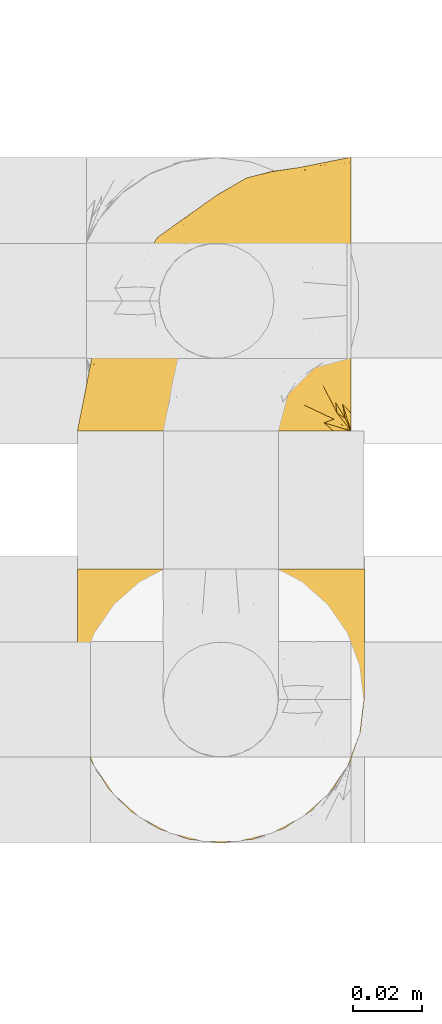
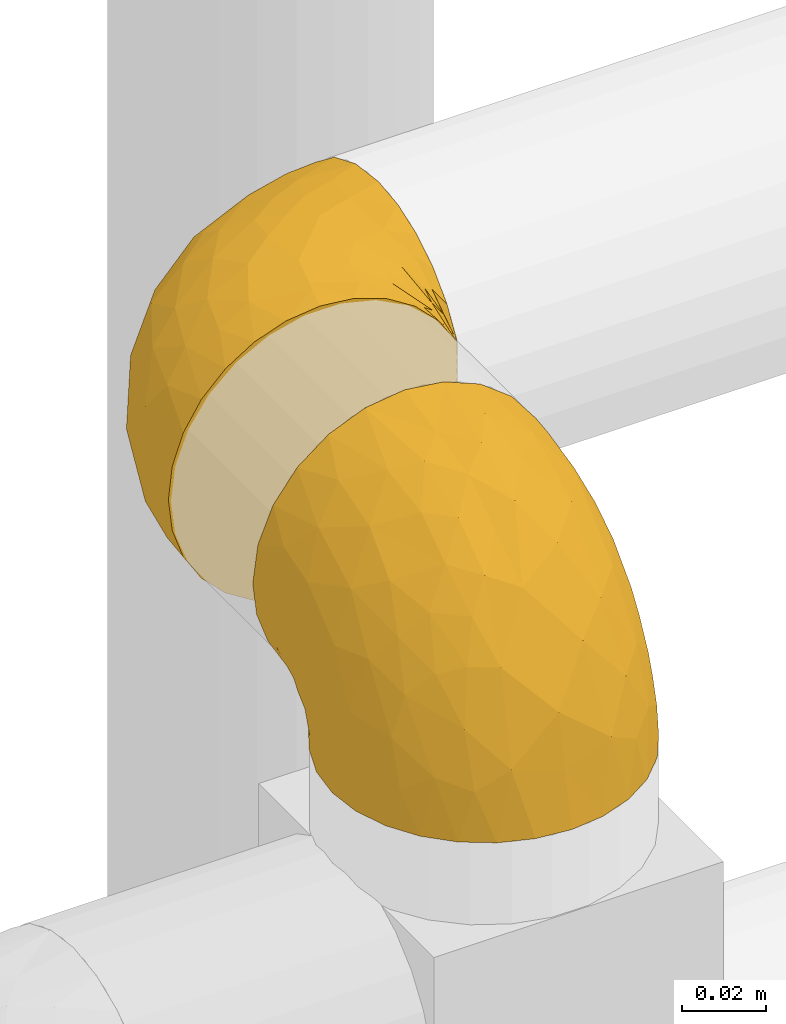
# One storey, part 443 of 827: 2 coverings.
"""IFC2X3 building model written with IfcOpenShell, lengths in millimetres."""

from ifc_helpers import new_model, entity, si_unit, converted_unit, derived_unit, direction, frame, origin, place, context, subcontext, project, spatial, faceted_brep, element, save


model = new_model("IFC2X3")

# Units and contexts
model_context = context("Model", 3, precision=0.01, world=origin(), true_north=direction((6.12303176911189e-17, 1.0)))
body_context = subcontext(model_context, "Body", "Model", "MODEL_VIEW")
ifc_project = project(units=[si_unit("LENGTHUNIT", "METRE", prefix="MILLI"), si_unit("AREAUNIT", "SQUARE_METRE"), si_unit("VOLUMEUNIT", "CUBIC_METRE"), converted_unit("PLANEANGLEUNIT", "DEGREE", entity("IfcRatioMeasure", 0.0174532925199433), si_unit("PLANEANGLEUNIT", "RADIAN"), dimensions=[0, 0, 0, 0, 0, 0, 0]), si_unit("MASSUNIT", "GRAM", prefix="KILO"), derived_unit("MASSDENSITYUNIT", [(si_unit("MASSUNIT", "GRAM", prefix="KILO"), 1), (si_unit("LENGTHUNIT", "METRE"), -3)]), derived_unit("MOMENTOFINERTIAUNIT", [(si_unit("LENGTHUNIT", "METRE"), 4)]), si_unit("TIMEUNIT", "SECOND"), si_unit("FREQUENCYUNIT", "HERTZ"), si_unit("THERMODYNAMICTEMPERATUREUNIT", "DEGREE_CELSIUS"), derived_unit("THERMALTRANSMITTANCEUNIT", [(si_unit("MASSUNIT", "GRAM", prefix="KILO"), 1), (si_unit("THERMODYNAMICTEMPERATUREUNIT", "KELVIN"), -1), (si_unit("TIMEUNIT", "SECOND"), -3)]), derived_unit("VOLUMETRICFLOWRATEUNIT", [(si_unit("LENGTHUNIT", "METRE"), 3), (si_unit("TIMEUNIT", "SECOND"), -1)]), derived_unit("MASSFLOWRATEUNIT", [(si_unit("MASSUNIT", "GRAM", prefix="KILO"), 1), (si_unit("TIMEUNIT", "SECOND"), -1)]), derived_unit("ROTATIONALFREQUENCYUNIT", [(si_unit("TIMEUNIT", "SECOND"), -1)]), si_unit("ELECTRICCURRENTUNIT", "AMPERE"), si_unit("ELECTRICVOLTAGEUNIT", "VOLT"), si_unit("POWERUNIT", "WATT"), si_unit("FORCEUNIT", "NEWTON", prefix="KILO"), si_unit("ILLUMINANCEUNIT", "LUX"), si_unit("LUMINOUSFLUXUNIT", "LUMEN"), si_unit("LUMINOUSINTENSITYUNIT", "CANDELA"), derived_unit("USERDEFINED", [(si_unit("MASSUNIT", "GRAM", prefix="KILO"), -1), (si_unit("LENGTHUNIT", "METRE"), -2), (si_unit("TIMEUNIT", "SECOND"), 3), (si_unit("LUMINOUSFLUXUNIT", "LUMEN"), 1)]), derived_unit("LINEARVELOCITYUNIT", [(si_unit("LENGTHUNIT", "METRE"), 1), (si_unit("TIMEUNIT", "SECOND"), -1)]), si_unit("PRESSUREUNIT", "PASCAL"), derived_unit("USERDEFINED", [(si_unit("LENGTHUNIT", "METRE"), -2), (si_unit("MASSUNIT", "GRAM", prefix="KILO"), 1), (si_unit("TIMEUNIT", "SECOND"), -2)]), derived_unit("LINEARFORCEUNIT", [(si_unit("MASSUNIT", "GRAM", prefix="KILO"), 1), (si_unit("LENGTHUNIT", "METRE"), 1), (si_unit("TIMEUNIT", "SECOND"), -2), (si_unit("LENGTHUNIT", "METRE"), -1)]), derived_unit("PLANARFORCEUNIT", [(si_unit("MASSUNIT", "GRAM", prefix="KILO"), 1), (si_unit("LENGTHUNIT", "METRE"), 1), (si_unit("TIMEUNIT", "SECOND"), -2), (si_unit("LENGTHUNIT", "METRE"), -2)])], contexts=[model_context])

# Site, building, storey
site_placement = place(None, origin())
site = spatial("IfcSite", under=ifc_project, at=site_placement, CompositionType="ELEMENT")
building_placement = place(site_placement, origin())
building = spatial("IfcBuilding", under=site, at=building_placement, CompositionType="ELEMENT")
storey_placement = place(building_placement, frame((0.0, 0.0, 28200.0)))
storey = spatial("IfcBuildingStorey", under=building, at=storey_placement, Name="08", CompositionType="ELEMENT", Elevation=28200.0)

# Coverings
covering_1_placement = place(storey_placement, frame((58981.69, 15520.93, 2656.55)))
element("IfcCovering", 1, at=covering_1_placement, inside=storey, Name=":ADSK_", ObjectType=":ADSK_", PredefinedType="INSULATION", context=body_context, shape_type="Brep", body=[
    faceted_brep([(25.28, 1.6, 81.15), (17.35, 1.6, 76.16), (10.72, 1.6, 69.53), (5.74, 1.6, 61.6), (2.64, 1.6, 52.75), (1.6, 1.6, 43.45), (2.65, 1.6, 34.13), (5.74, 1.6, 25.28), (10.73, 1.6, 17.35), (17.36, 1.6, 10.72), (25.29, 1.6, 5.74), (34.14, 1.6, 2.64), (43.45, 1.6, 1.6), (52.82, 1.6, 2.66), (61.71, 1.6, 5.79), (69.67, 1.6, 10.83), (76.31, 1.6, 17.53), (81.27, 1.6, 25.53), (81.27, 1.6, 26.45), (81.27, 1.6, 27.37), (81.27, 1.6, 28.17), (81.27, 1.6, 29.49), (81.27, 1.6, 30.81), (81.27, 1.6, 32.13), (81.27, 1.6, 33.45), (81.27, 1.6, 34.78), (81.27, 1.6, 36.1), (81.27, 1.6, 37.42), (81.27, 1.6, 38.74), (81.27, 1.6, 40.06), (81.27, 1.6, 41.38), (81.27, 1.6, 42.7), (81.27, 1.6, 44.02), (81.27, 1.6, 45.34), (81.27, 1.6, 46.66), (81.27, 1.6, 47.58), (81.27, 1.6, 48.5), (81.27, 1.6, 49.41), (81.27, 1.6, 50.33), (81.27, 1.6, 51.25), (81.27, 1.6, 52.17), (81.27, 1.6, 53.09), (81.27, 1.6, 54.01), (81.27, 1.6, 54.93), (81.27, 1.6, 55.85), (81.27, 1.6, 56.76), (81.27, 1.6, 57.68), (81.27, 1.6, 58.6), (81.27, 1.6, 59.52), (81.27, 1.6, 60.44), (81.27, 1.6, 61.36), (76.3, 1.6, 69.37), (69.66, 1.6, 76.07), (61.69, 1.6, 81.11), (52.8, 1.6, 84.24), (43.45, 1.6, 85.3), (34.13, 1.6, 84.24), (81.45, 6.74, 17.52), (81.45, 13.37, 10.83), (81.45, 21.34, 5.79), (81.45, 30.23, 2.66), (81.45, 39.6, 1.6), (81.45, 50.43, 3.02), (81.45, 60.52, 7.2), (81.45, 69.19, 13.85), (81.45, 75.84, 22.52), (81.45, 80.02, 32.61), (81.45, 81.45, 43.45), (81.45, 80.02, 54.28), (81.45, 75.84, 64.37), (81.45, 69.19, 73.04), (81.45, 60.52, 79.69), (81.45, 50.43, 83.87), (81.45, 39.6, 85.3), (81.45, 30.23, 84.23), (81.45, 21.34, 81.1), (81.45, 13.37, 76.06), (81.45, 6.74, 69.37), (81.45, 1.77, 61.36), (81.45, 1.77, 60.44), (81.45, 1.77, 59.12), (81.45, 1.77, 58.0), (81.45, 1.77, 56.88), (81.45, 1.77, 55.76), (81.45, 1.77, 54.64), (81.45, 1.77, 53.52), (81.45, 1.77, 52.4), (81.45, 1.77, 51.28), (81.45, 1.77, 50.16), (81.45, 1.77, 49.04), (81.45, 1.77, 47.92), (81.45, 1.77, 46.8), (81.45, 1.77, 45.68), (81.45, 1.77, 44.56), (81.45, 1.77, 43.45), (81.45, 1.77, 42.12), (81.45, 1.77, 40.8), (81.45, 1.77, 39.48), (81.45, 1.77, 38.16), (81.45, 1.77, 36.84), (81.45, 1.77, 35.52), (81.45, 1.77, 34.2), (81.45, 1.77, 32.88), (81.45, 1.77, 31.96), (81.45, 1.77, 31.05), (81.45, 1.77, 30.13), (81.45, 1.77, 29.21), (81.45, 1.77, 28.29), (81.45, 1.77, 27.37), (81.45, 1.77, 26.45), (81.45, 1.77, 25.53), (81.33, 1.73, 54.08), (81.32, 1.72, 55.16), (81.33, 1.73, 36.18), (81.32, 1.72, 35.13), (81.33, 1.73, 44.01), (81.32, 1.73, 45.08), (81.32, 1.72, 61.36), (81.32, 1.72, 59.98), (81.32, 1.72, 46.18), (81.32, 1.72, 26.74), (81.32, 1.72, 47.36), (81.32, 1.73, 29.67), (81.34, 1.74, 28.72), (81.32, 1.72, 39.77), (81.31, 1.71, 52.96), (81.33, 1.73, 51.84), (81.31, 1.71, 40.8), (81.32, 1.72, 41.87), (81.33, 1.73, 42.94), (81.32, 1.72, 27.77), (81.33, 1.73, 48.4), (81.32, 1.72, 37.21), (81.33, 1.73, 33.54), (81.32, 1.72, 32.49), (81.32, 1.72, 30.69), (81.32, 1.72, 50.69), (81.31, 1.71, 49.6), (81.32, 1.72, 56.32), (81.33, 1.73, 57.44), (81.31, 1.71, 58.88), (81.32, 1.72, 25.53), (81.3, 1.68, 61.36), (81.29, 1.64, 61.36), (81.29, 1.64, 25.53), (81.3, 1.68, 25.53), (81.4, 1.75, 61.36), (81.36, 1.74, 61.36), (81.36, 1.74, 25.53), (81.4, 1.75, 25.53), (81.3, 1.7, 31.59), (81.33, 1.73, 38.71), (74.06, 24.54, 3.97), (45.99, 11.1, 1.6), (58.35, 8.47, 3.97), (67.76, 9.11, 8.09), (66.18, 4.86, 8.09), (76.46, 5.0, 16.43), (77.33, 6.81, 15.73), (71.95, 37.05, 1.6), (72.25, 9.03, 10.79), (78.91, 9.47, 13.99), (76.42, 16.39, 8.08), (73.52, 3.95, 14.0), (76.9, 9.9, 12.83), (65.25, 22.7, 3.18), (62.45, 34.5, 1.6), (74.31, 37.68, 1.6), (59.38, 15.82, 3.28), (48.54, 20.6, 1.6), (67.72, 14.37, 6.28), (55.49, 27.55, 1.6), (79.73, 5.2, 19.06), (73.23, 14.88, 8.08), (45.36, 8.73, 1.6), (15.81, 44.27, 32.11), (6.4, 20.94, 29.62), (7.67, 32.15, 43.45), (68.46, 46.13, 2.45), (59.33, 42.67, 2.5), (48.7, 55.18, 9.73), (53.94, 67.27, 17.97), (65.02, 62.91, 10.24), (60.77, 51.5, 4.78), (72.07, 54.79, 4.78), (26.25, 25.78, 8.01), (22.29, 13.05, 8.01), (16.0, 18.46, 13.85), (46.93, 32.4, 2.42), (14.19, 31.07, 21.17), (58.46, 77.32, 35.73), (61.51, 75.62, 27.43), (4.64, 16.9, 43.45), (68.93, 71.69, 17.97), (29.62, 61.4, 35.71), (24.85, 54.47, 29.47), (38.55, 27.66, 3.41), (31.27, 14.53, 3.94), (9.35, 15.56, 21.17), (37.15, 42.26, 7.92), (47.07, 41.51, 4.25), (26.49, 36.93, 11.75), (23.01, 42.72, 18.31), (19.4, 44.68, 24.94), (48.06, 71.2, 28.78), (42.46, 70.48, 35.82), (50.89, 75.37, 43.45), (35.78, 63.65, 28.38), (24.98, 58.06, 43.45), (16.33, 45.11, 43.45), (66.14, 78.4, 43.45), (30.96, 54.95, 21.21), (41.83, 59.31, 16.48), (33.28, 49.01, 13.85), (37.94, 66.71, 43.45), (67.39, 53.75, 82.11), (58.47, 77.27, 51.41), (32.5, 61.6, 57.45), (15.79, 44.24, 54.78), (15.99, 18.46, 73.03), (9.34, 15.55, 65.7), (56.91, 60.14, 76.65), (63.5, 70.5, 68.92), (44.08, 63.0, 68.01), (26.24, 25.78, 78.88), (22.27, 13.05, 78.88), (31.26, 14.53, 82.94), (23.95, 48.5, 64.44), (63.79, 44.23, 84.49), (62.45, 34.5, 85.3), (71.95, 37.05, 85.3), (45.36, 8.73, 85.3), (67.83, 77.68, 57.84), (70.28, 64.08, 76.65), (42.11, 70.25, 51.19), (6.39, 20.93, 57.26), (43.54, 49.9, 78.14), (58.03, 49.6, 82.35), (14.18, 31.06, 65.7), (56.34, 39.62, 84.61), (48.09, 34.42, 84.36), (48.54, 20.6, 85.3), (55.49, 27.55, 85.3), (21.78, 33.36, 73.03), (38.54, 27.68, 83.48), (45.99, 11.1, 85.3), (72.79, 46.67, 84.54), (33.26, 49.0, 73.03), (35.53, 38.94, 79.54), (53.66, 73.05, 59.46), (43.03, 56.63, 73.5), (49.68, 43.85, 82.57), (74.06, 24.54, 82.92), (59.37, 15.82, 83.62), (58.34, 8.47, 82.92), (67.75, 9.12, 78.81), (78.91, 9.47, 72.9), (76.9, 9.91, 74.06), (78.08, 16.85, 78.81), (73.23, 14.88, 78.81), (79.73, 5.2, 67.83), (77.34, 6.81, 71.15), (73.51, 3.96, 72.91), (76.45, 5.0, 70.47), (66.41, 5.86, 78.81), (67.7, 14.38, 80.62), (72.24, 9.04, 76.11), (65.25, 22.7, 83.71)], [[[0, 1, 2, 3, 4, 5, 6, 7, 8, 9, 10, 11, 12, 13, 14, 15, 16, 17, 18, 19, 20, 21, 22, 23, 24, 25, 26, 27, 28, 29, 30, 31, 32, 33, 34, 35, 36, 37, 38, 39, 40, 41, 42, 43, 44, 45, 46, 47, 48, 49, 50, 51, 52, 53, 54, 55, 56]], [[57, 58, 59, 60, 61, 62, 63, 64, 65, 66, 67, 68, 69, 70, 71, 72, 73, 74, 75, 76, 77, 78, 79, 80, 81, 82, 83, 84, 85, 86, 87, 88, 89, 90, 91, 92, 93, 94, 95, 96, 97, 98, 99, 100, 101, 102, 103, 104, 105, 106, 107, 108, 109, 110]], [[111, 84, 112]], [[113, 26, 114]], [[114, 101, 100]], [[115, 93, 116]], [[79, 117, 118]], [[33, 116, 119]], [[117, 49, 118]], [[19, 18, 120]], [[119, 121, 34]], [[122, 21, 123]], [[97, 96, 124]], [[86, 125, 126]], [[116, 92, 119]], [[127, 96, 128]], [[32, 129, 115]], [[19, 120, 130]], [[121, 90, 131]], [[94, 115, 129]], [[115, 116, 32]], [[118, 49, 48]], [[113, 99, 132]], [[133, 114, 25]], [[24, 134, 133]], [[135, 22, 122]], [[136, 137, 88]], [[84, 83, 112]], [[138, 82, 139]], [[130, 20, 19]], [[118, 48, 140]], [[81, 140, 139]], [[123, 21, 20]], [[141, 120, 18]], [[139, 82, 81]], [[130, 107, 123]], [[49, 117, 142, 143, 50]], [[18, 17, 144, 145, 141]], [[79, 78, 146, 147, 117]], [[109, 141, 148, 149, 110]], [[102, 133, 134]], [[105, 135, 122]], [[118, 80, 79]], [[80, 118, 140]], [[120, 109, 108]], [[47, 46, 140, 48]], [[81, 80, 140]], [[44, 112, 138]], [[93, 115, 94]], [[46, 139, 140]], [[46, 45, 139]], [[139, 45, 138]], [[138, 112, 83]], [[85, 84, 111]], [[112, 43, 111]], [[83, 82, 138]], [[106, 122, 123]], [[105, 122, 106]], [[21, 122, 22]], [[124, 29, 28]], [[33, 32, 116]], [[128, 129, 31]], [[32, 31, 129]], [[34, 33, 119]], [[116, 93, 92]], [[129, 95, 94]], [[95, 129, 128]], [[41, 40, 125, 42]], [[119, 91, 121]], [[36, 35, 131, 37]], [[137, 131, 89]], [[121, 131, 35]], [[90, 121, 91]], [[119, 92, 91]], [[136, 126, 39]], [[125, 86, 85]], [[42, 125, 111]], [[85, 111, 125]], [[150, 23, 22]], [[130, 108, 107]], [[130, 123, 20]], [[107, 106, 123]], [[137, 37, 131]], [[136, 38, 137]], [[89, 88, 137]], [[131, 90, 89]], [[124, 151, 97]], [[40, 39, 126]], [[87, 126, 136]], [[86, 126, 87]], [[136, 88, 87]], [[40, 126, 125]], [[39, 38, 136]], [[95, 128, 96]], [[30, 128, 31]], [[29, 124, 127]], [[127, 128, 30]], [[151, 124, 28]], [[127, 30, 29]], [[127, 124, 96]], [[151, 98, 97]], [[45, 44, 138]], [[26, 113, 132]], [[113, 100, 99]], [[132, 151, 27]], [[27, 26, 132]], [[26, 25, 114]], [[100, 113, 114]], [[101, 133, 102]], [[133, 101, 114]], [[28, 27, 151]], [[132, 99, 98]], [[23, 134, 24]], [[25, 24, 133]], [[134, 23, 150]], [[135, 104, 150]], [[150, 104, 103]], [[103, 102, 134]], [[130, 120, 108]], [[109, 120, 141]], [[42, 111, 43]], [[112, 44, 43]], [[104, 135, 105]], [[134, 150, 103]], [[135, 150, 22]], [[35, 34, 121]], [[137, 38, 37]], [[98, 151, 132]], [[59, 152, 60]], [[13, 153, 154]], [[155, 156, 154]], [[157, 158, 141]], [[159, 60, 152]], [[160, 157, 155]], [[161, 162, 58]], [[58, 162, 59]], [[144, 16, 163]], [[58, 57, 161]], [[162, 161, 164]], [[157, 163, 155]], [[163, 16, 15]], [[57, 149, 161]], [[152, 165, 166]], [[157, 144, 163]], [[60, 159, 167, 61]], [[156, 14, 154]], [[163, 156, 155]], [[155, 154, 168]], [[168, 154, 169]], [[155, 170, 160]], [[57, 110, 149]], [[144, 17, 16]], [[156, 15, 14]], [[171, 165, 168]], [[158, 164, 172]], [[14, 13, 154]], [[157, 141, 145, 144]], [[173, 164, 158]], [[173, 160, 170]], [[171, 166, 165]], [[168, 165, 170]], [[168, 169, 171]], [[152, 173, 165]], [[170, 155, 168]], [[165, 173, 170]], [[160, 173, 158]], [[172, 149, 148]], [[148, 141, 158]], [[158, 157, 160]], [[152, 166, 159]], [[173, 152, 162]], [[59, 162, 152]], [[13, 12, 174, 153]], [[153, 169, 154]], [[15, 156, 163]], [[162, 164, 173]], [[172, 164, 161]], [[149, 172, 161]], [[158, 172, 148]], [[175, 176, 177]], [[178, 166, 179]], [[180, 181, 182]], [[183, 184, 178]], [[185, 186, 187]], [[171, 188, 179]], [[174, 12, 11]], [[189, 176, 175]], [[190, 66, 191]], [[176, 6, 192]], [[193, 65, 64]], [[63, 184, 182]], [[63, 182, 64]], [[65, 193, 191]], [[184, 63, 62]], [[175, 194, 195]], [[196, 169, 197]], [[174, 11, 197]], [[8, 7, 198]], [[187, 9, 8]], [[197, 169, 153, 174]], [[197, 11, 10]], [[186, 197, 10]], [[199, 180, 200]], [[197, 185, 196]], [[201, 189, 202]], [[201, 187, 189]], [[195, 203, 175]], [[191, 204, 190]], [[176, 7, 6]], [[177, 176, 192]], [[189, 198, 176]], [[65, 191, 66]], [[198, 187, 8]], [[205, 206, 190]], [[9, 186, 10]], [[181, 207, 204]], [[208, 175, 177, 209]], [[66, 190, 210]], [[211, 212, 213]], [[190, 204, 205]], [[180, 182, 183]], [[193, 182, 181]], [[62, 61, 167]], [[196, 185, 199]], [[196, 200, 188]], [[6, 5, 192]], [[176, 198, 7]], [[187, 198, 189]], [[187, 186, 9]], [[197, 186, 185]], [[200, 180, 183]], [[180, 213, 212]], [[179, 183, 178]], [[185, 201, 199]], [[210, 190, 206]], [[210, 67, 66]], [[205, 204, 207]], [[194, 205, 207]], [[194, 214, 205]], [[195, 194, 207]], [[208, 194, 175]], [[207, 211, 195]], [[202, 203, 211]], [[212, 207, 181]], [[202, 211, 213]], [[201, 202, 213]], [[189, 175, 203]], [[199, 201, 213]], [[187, 201, 185]], [[180, 199, 213]], [[196, 199, 200]], [[211, 203, 195]], [[189, 203, 202]], [[207, 212, 211]], [[180, 212, 181]], [[214, 194, 208]], [[214, 206, 205]], [[196, 188, 169]], [[181, 204, 191]], [[182, 193, 64]], [[191, 193, 181]], [[178, 62, 167]], [[182, 184, 183]], [[62, 178, 184]], [[178, 167, 159, 166]], [[171, 179, 166]], [[200, 183, 179]], [[179, 188, 200]], [[169, 188, 171]], [[71, 215, 72]], [[206, 216, 210]], [[217, 208, 218]], [[216, 68, 210]], [[219, 220, 2]], [[221, 222, 223]], [[224, 225, 226]], [[227, 223, 217]], [[228, 229, 230]], [[56, 231, 226]], [[232, 222, 69]], [[56, 55, 231]], [[70, 233, 71]], [[71, 233, 215]], [[0, 56, 226]], [[208, 217, 234]], [[218, 177, 235]], [[221, 236, 237]], [[238, 220, 219]], [[1, 219, 2]], [[68, 216, 232]], [[235, 3, 220]], [[235, 192, 4]], [[1, 0, 225]], [[228, 239, 229]], [[240, 241, 242]], [[243, 238, 219]], [[224, 226, 244]], [[226, 241, 244]], [[3, 235, 4]], [[69, 222, 70]], [[225, 219, 1]], [[218, 235, 238]], [[243, 219, 224]], [[218, 227, 217]], [[3, 2, 220]], [[218, 208, 209, 177]], [[226, 231, 245, 241]], [[215, 228, 246]], [[247, 248, 236]], [[248, 224, 244]], [[223, 222, 249]], [[233, 222, 221]], [[242, 239, 240]], [[248, 247, 243]], [[217, 223, 249]], [[250, 247, 236]], [[216, 234, 249]], [[218, 238, 227]], [[192, 235, 177]], [[192, 5, 4]], [[72, 246, 73]], [[235, 220, 238]], [[226, 225, 0]], [[219, 225, 224]], [[240, 248, 244]], [[239, 242, 229]], [[236, 248, 251]], [[68, 67, 210]], [[234, 216, 206]], [[216, 249, 232]], [[234, 206, 214, 208]], [[249, 234, 217]], [[222, 232, 249]], [[69, 68, 232]], [[246, 228, 230]], [[237, 228, 215]], [[243, 227, 238]], [[223, 227, 247]], [[73, 246, 230]], [[215, 246, 72]], [[248, 243, 224]], [[227, 243, 247]], [[237, 236, 251]], [[250, 221, 223]], [[222, 233, 70]], [[215, 233, 221]], [[221, 237, 215]], [[239, 237, 251]], [[237, 239, 228]], [[239, 251, 240]], [[248, 240, 251]], [[241, 240, 244]], [[221, 250, 236]], [[223, 247, 250]], [[74, 230, 252]], [[253, 254, 255]], [[146, 77, 256]], [[257, 258, 259]], [[260, 256, 257]], [[260, 261, 147]], [[75, 74, 252]], [[51, 143, 262]], [[263, 143, 142, 117]], [[256, 77, 76]], [[252, 258, 75]], [[253, 241, 254]], [[254, 245, 54]], [[258, 256, 76]], [[53, 52, 264]], [[255, 265, 253]], [[254, 264, 255]], [[255, 264, 262]], [[75, 258, 76]], [[265, 255, 266]], [[255, 262, 263]], [[51, 50, 143]], [[54, 245, 231, 55]], [[51, 262, 52]], [[253, 267, 242]], [[254, 54, 53]], [[266, 259, 265]], [[146, 78, 77]], [[263, 117, 261]], [[146, 256, 260]], [[257, 259, 261]], [[267, 253, 265]], [[229, 267, 252]], [[242, 267, 229]], [[242, 241, 253]], [[252, 267, 259]], [[255, 263, 266]], [[259, 267, 265]], [[261, 117, 147]], [[263, 261, 266]], [[259, 266, 261]], [[230, 74, 73]], [[230, 229, 252]], [[259, 258, 252]], [[254, 241, 245]], [[53, 264, 254]], [[52, 262, 264]], [[143, 263, 262]], [[258, 257, 256]], [[261, 260, 257]], [[146, 260, 147]]]),
])
covering_2_placement = place(storey_placement, frame((58981.69, 15400.76, 2660.4)))
element("IfcCovering", 2, at=covering_2_placement, inside=storey, Name=":ADSK_", ObjectType=":ADSK_", PredefinedType="INSULATION", context=body_context, shape_type="Brep", body=[
    faceted_brep([(81.15, 25.28, 1.6), (76.16, 17.35, 1.6), (69.53, 10.72, 1.6), (61.6, 5.74, 1.6), (52.75, 2.64, 1.6), (43.45, 1.6, 1.6), (34.13, 2.65, 1.6), (25.28, 5.74, 1.6), (17.35, 10.73, 1.6), (10.72, 17.36, 1.6), (5.74, 25.29, 1.6), (2.64, 34.14, 1.6), (1.6, 43.45, 1.6), (2.66, 52.82, 1.6), (5.79, 61.71, 1.6), (10.83, 69.67, 1.6), (17.53, 76.31, 1.6), (25.53, 81.27, 1.6), (26.45, 81.27, 1.6), (27.37, 81.27, 1.6), (28.17, 81.27, 1.6), (29.49, 81.27, 1.6), (30.81, 81.27, 1.6), (32.13, 81.27, 1.6), (33.45, 81.27, 1.6), (34.78, 81.27, 1.6), (36.1, 81.27, 1.6), (37.42, 81.27, 1.6), (38.74, 81.27, 1.6), (40.06, 81.27, 1.6), (41.38, 81.27, 1.6), (42.7, 81.27, 1.6), (44.02, 81.27, 1.6), (45.34, 81.27, 1.6), (46.66, 81.27, 1.6), (47.58, 81.27, 1.6), (48.5, 81.27, 1.6), (49.41, 81.27, 1.6), (50.33, 81.27, 1.6), (51.25, 81.27, 1.6), (52.17, 81.27, 1.6), (53.09, 81.27, 1.6), (54.01, 81.27, 1.6), (54.93, 81.27, 1.6), (55.85, 81.27, 1.6), (56.76, 81.27, 1.6), (57.68, 81.27, 1.6), (58.6, 81.27, 1.6), (59.52, 81.27, 1.6), (60.44, 81.27, 1.6), (61.36, 81.27, 1.6), (69.37, 76.3, 1.6), (76.07, 69.66, 1.6), (81.11, 61.69, 1.6), (84.24, 52.8, 1.6), (85.3, 43.45, 1.6), (84.24, 34.13, 1.6), (17.52, 81.45, 6.74), (10.83, 81.45, 13.37), (5.79, 81.45, 21.34), (2.66, 81.45, 30.23), (1.6, 81.45, 39.6), (3.02, 81.45, 50.43), (7.2, 81.45, 60.52), (13.85, 81.45, 69.19), (22.52, 81.45, 75.84), (32.61, 81.45, 80.02), (43.45, 81.45, 81.45), (54.28, 81.45, 80.02), (64.37, 81.45, 75.84), (73.04, 81.45, 69.19), (79.69, 81.45, 60.52), (83.87, 81.45, 50.43), (85.3, 81.45, 39.6), (84.23, 81.45, 30.23), (81.1, 81.45, 21.34), (76.06, 81.45, 13.37), (69.37, 81.45, 6.74), (61.36, 81.45, 1.77), (60.44, 81.45, 1.77), (59.12, 81.45, 1.77), (58.0, 81.45, 1.77), (56.88, 81.45, 1.77), (55.76, 81.45, 1.77), (54.64, 81.45, 1.77), (53.52, 81.45, 1.77), (52.4, 81.45, 1.77), (51.28, 81.45, 1.77), (50.16, 81.45, 1.77), (49.04, 81.45, 1.77), (47.92, 81.45, 1.77), (46.8, 81.45, 1.77), (45.68, 81.45, 1.77), (44.56, 81.45, 1.77), (43.45, 81.45, 1.77), (42.12, 81.45, 1.77), (40.8, 81.45, 1.77), (39.48, 81.45, 1.77), (38.16, 81.45, 1.77), (36.84, 81.45, 1.77), (35.52, 81.45, 1.77), (34.2, 81.45, 1.77), (32.88, 81.45, 1.77), (31.96, 81.45, 1.77), (31.05, 81.45, 1.77), (30.13, 81.45, 1.77), (29.21, 81.45, 1.77), (28.29, 81.45, 1.77), (27.37, 81.45, 1.77), (26.45, 81.45, 1.77), (25.53, 81.45, 1.77), (54.08, 81.33, 1.73), (55.16, 81.32, 1.72), (36.18, 81.33, 1.73), (35.13, 81.32, 1.72), (44.01, 81.33, 1.73), (45.08, 81.32, 1.73), (61.36, 81.32, 1.72), (59.98, 81.32, 1.72), (46.18, 81.32, 1.72), (26.74, 81.32, 1.72), (47.36, 81.32, 1.72), (29.67, 81.32, 1.73), (28.72, 81.34, 1.74), (39.77, 81.32, 1.72), (52.96, 81.31, 1.71), (51.84, 81.33, 1.73), (40.8, 81.31, 1.71), (41.87, 81.32, 1.72), (42.94, 81.33, 1.73), (27.77, 81.32, 1.72), (48.4, 81.33, 1.73), (37.21, 81.32, 1.72), (33.54, 81.33, 1.73), (32.49, 81.32, 1.72), (30.69, 81.32, 1.72), (50.69, 81.32, 1.72), (49.6, 81.31, 1.71), (56.32, 81.32, 1.72), (57.44, 81.33, 1.73), (58.88, 81.31, 1.71), (25.53, 81.32, 1.72), (61.36, 81.3, 1.68), (61.36, 81.29, 1.64), (25.53, 81.29, 1.64), (25.53, 81.3, 1.68), (61.36, 81.4, 1.75), (61.36, 81.36, 1.74), (25.53, 81.36, 1.74), (25.53, 81.4, 1.75), (31.59, 81.3, 1.7), (38.71, 81.33, 1.73), (3.97, 74.06, 24.54), (1.6, 45.99, 11.1), (3.97, 58.35, 8.47), (8.09, 67.76, 9.11), (8.09, 66.18, 4.86), (16.43, 76.46, 5.0), (15.73, 77.33, 6.81), (1.6, 71.95, 37.05), (10.79, 72.25, 9.03), (13.99, 78.91, 9.47), (8.08, 76.42, 16.39), (14.0, 73.52, 3.95), (12.83, 76.9, 9.9), (3.18, 65.25, 22.7), (1.6, 62.45, 34.5), (1.6, 74.31, 37.68), (3.28, 59.38, 15.82), (1.6, 48.54, 20.6), (6.28, 67.72, 14.37), (1.6, 55.49, 27.55), (19.06, 79.73, 5.2), (8.08, 73.23, 14.88), (1.6, 45.36, 8.73), (32.11, 15.81, 44.27), (29.62, 6.4, 20.94), (43.45, 7.67, 32.15), (2.45, 68.46, 46.13), (2.5, 59.33, 42.67), (9.73, 48.7, 55.18), (17.97, 53.94, 67.27), (10.24, 65.02, 62.91), (4.78, 60.77, 51.5), (4.78, 72.07, 54.79), (8.01, 26.25, 25.78), (8.01, 22.29, 13.05), (13.85, 16.0, 18.46), (2.42, 46.93, 32.4), (21.17, 14.19, 31.07), (35.73, 58.46, 77.32), (27.43, 61.51, 75.62), (43.45, 4.64, 16.9), (17.97, 68.93, 71.69), (35.71, 29.62, 61.4), (29.47, 24.85, 54.47), (3.41, 38.55, 27.66), (3.94, 31.27, 14.53), (21.17, 9.35, 15.56), (7.92, 37.15, 42.26), (4.25, 47.07, 41.51), (11.75, 26.49, 36.93), (18.31, 23.01, 42.72), (24.94, 19.4, 44.68), (28.78, 48.06, 71.2), (35.82, 42.46, 70.48), (43.45, 50.89, 75.37), (28.38, 35.78, 63.65), (43.45, 24.98, 58.06), (43.45, 16.33, 45.11), (43.45, 66.14, 78.4), (21.21, 30.96, 54.95), (16.48, 41.83, 59.31), (13.85, 33.28, 49.01), (43.45, 37.94, 66.71), (82.11, 67.39, 53.75), (51.41, 58.47, 77.27), (57.45, 32.5, 61.6), (54.78, 15.79, 44.24), (73.03, 15.99, 18.46), (65.7, 9.34, 15.55), (76.65, 56.91, 60.14), (68.92, 63.5, 70.5), (68.01, 44.08, 63.0), (78.88, 26.24, 25.78), (78.88, 22.27, 13.05), (82.94, 31.26, 14.53), (64.44, 23.95, 48.5), (84.49, 63.79, 44.23), (85.3, 62.45, 34.5), (85.3, 71.95, 37.05), (85.3, 45.36, 8.73), (57.84, 67.83, 77.68), (76.65, 70.28, 64.08), (51.19, 42.11, 70.25), (57.26, 6.39, 20.93), (78.14, 43.54, 49.9), (82.35, 58.03, 49.6), (65.7, 14.18, 31.06), (84.61, 56.34, 39.62), (84.36, 48.09, 34.42), (85.3, 48.54, 20.6), (85.3, 55.49, 27.55), (73.03, 21.78, 33.36), (83.48, 38.54, 27.68), (85.3, 45.99, 11.1), (84.54, 72.79, 46.67), (73.03, 33.26, 49.0), (79.54, 35.53, 38.94), (59.46, 53.66, 73.05), (73.5, 43.03, 56.63), (82.57, 49.68, 43.85), (82.92, 74.06, 24.54), (83.62, 59.37, 15.82), (82.92, 58.34, 8.47), (78.81, 67.75, 9.12), (72.9, 78.91, 9.47), (74.06, 76.9, 9.91), (78.81, 78.08, 16.85), (78.81, 73.23, 14.88), (67.83, 79.73, 5.2), (71.15, 77.34, 6.81), (72.91, 73.51, 3.96), (70.47, 76.45, 5.0), (78.81, 66.41, 5.86), (80.62, 67.7, 14.38), (76.11, 72.24, 9.04), (83.71, 65.25, 22.7)], [[[0, 1, 2, 3, 4, 5, 6, 7, 8, 9, 10, 11, 12, 13, 14, 15, 16, 17, 18, 19, 20, 21, 22, 23, 24, 25, 26, 27, 28, 29, 30, 31, 32, 33, 34, 35, 36, 37, 38, 39, 40, 41, 42, 43, 44, 45, 46, 47, 48, 49, 50, 51, 52, 53, 54, 55, 56]], [[57, 58, 59, 60, 61, 62, 63, 64, 65, 66, 67, 68, 69, 70, 71, 72, 73, 74, 75, 76, 77, 78, 79, 80, 81, 82, 83, 84, 85, 86, 87, 88, 89, 90, 91, 92, 93, 94, 95, 96, 97, 98, 99, 100, 101, 102, 103, 104, 105, 106, 107, 108, 109, 110]], [[111, 84, 112]], [[113, 26, 114]], [[114, 101, 100]], [[115, 93, 116]], [[79, 117, 118]], [[33, 116, 119]], [[117, 49, 118]], [[19, 18, 120]], [[119, 121, 34]], [[122, 21, 123]], [[97, 96, 124]], [[86, 125, 126]], [[116, 92, 119]], [[127, 96, 128]], [[32, 129, 115]], [[19, 120, 130]], [[121, 90, 131]], [[94, 115, 129]], [[115, 116, 32]], [[118, 49, 48]], [[113, 99, 132]], [[133, 114, 25]], [[24, 134, 133]], [[135, 22, 122]], [[136, 137, 88]], [[84, 83, 112]], [[138, 82, 139]], [[130, 20, 19]], [[118, 48, 140]], [[81, 140, 139]], [[123, 21, 20]], [[141, 120, 18]], [[139, 82, 81]], [[130, 107, 123]], [[49, 117, 142, 143, 50]], [[18, 17, 144, 145, 141]], [[79, 78, 146, 147, 117]], [[109, 141, 148, 149, 110]], [[102, 133, 134]], [[105, 135, 122]], [[118, 80, 79]], [[80, 118, 140]], [[120, 109, 108]], [[47, 46, 140, 48]], [[81, 80, 140]], [[44, 112, 138]], [[93, 115, 94]], [[46, 139, 140]], [[46, 45, 139]], [[139, 45, 138]], [[138, 112, 83]], [[85, 84, 111]], [[112, 43, 111]], [[83, 82, 138]], [[106, 122, 123]], [[105, 122, 106]], [[21, 122, 22]], [[124, 29, 28]], [[33, 32, 116]], [[128, 129, 31]], [[32, 31, 129]], [[34, 33, 119]], [[116, 93, 92]], [[129, 95, 94]], [[95, 129, 128]], [[41, 40, 125, 42]], [[119, 91, 121]], [[36, 35, 131, 37]], [[137, 131, 89]], [[121, 131, 35]], [[90, 121, 91]], [[119, 92, 91]], [[136, 126, 39]], [[125, 86, 85]], [[42, 125, 111]], [[85, 111, 125]], [[150, 23, 22]], [[130, 108, 107]], [[130, 123, 20]], [[107, 106, 123]], [[137, 37, 131]], [[136, 38, 137]], [[89, 88, 137]], [[131, 90, 89]], [[124, 151, 97]], [[40, 39, 126]], [[87, 126, 136]], [[86, 126, 87]], [[136, 88, 87]], [[40, 126, 125]], [[39, 38, 136]], [[95, 128, 96]], [[30, 128, 31]], [[29, 124, 127]], [[127, 128, 30]], [[151, 124, 28]], [[127, 30, 29]], [[127, 124, 96]], [[151, 98, 97]], [[45, 44, 138]], [[26, 113, 132]], [[113, 100, 99]], [[132, 151, 27]], [[27, 26, 132]], [[26, 25, 114]], [[100, 113, 114]], [[101, 133, 102]], [[133, 101, 114]], [[28, 27, 151]], [[132, 99, 98]], [[23, 134, 24]], [[25, 24, 133]], [[134, 23, 150]], [[135, 104, 150]], [[150, 104, 103]], [[103, 102, 134]], [[130, 120, 108]], [[109, 120, 141]], [[42, 111, 43]], [[112, 44, 43]], [[104, 135, 105]], [[134, 150, 103]], [[135, 150, 22]], [[35, 34, 121]], [[137, 38, 37]], [[98, 151, 132]], [[59, 152, 60]], [[13, 153, 154]], [[155, 156, 154]], [[157, 158, 141]], [[159, 60, 152]], [[160, 157, 155]], [[161, 162, 58]], [[58, 162, 59]], [[144, 16, 163]], [[58, 57, 161]], [[162, 161, 164]], [[157, 163, 155]], [[163, 16, 15]], [[57, 149, 161]], [[152, 165, 166]], [[157, 144, 163]], [[60, 159, 167, 61]], [[156, 14, 154]], [[163, 156, 155]], [[155, 154, 168]], [[168, 154, 169]], [[155, 170, 160]], [[57, 110, 149]], [[144, 17, 16]], [[156, 15, 14]], [[171, 165, 168]], [[158, 164, 172]], [[14, 13, 154]], [[157, 141, 145, 144]], [[173, 164, 158]], [[173, 160, 170]], [[171, 166, 165]], [[168, 165, 170]], [[168, 169, 171]], [[152, 173, 165]], [[170, 155, 168]], [[165, 173, 170]], [[160, 173, 158]], [[172, 149, 148]], [[148, 141, 158]], [[158, 157, 160]], [[152, 166, 159]], [[173, 152, 162]], [[59, 162, 152]], [[13, 12, 174, 153]], [[153, 169, 154]], [[15, 156, 163]], [[162, 164, 173]], [[172, 164, 161]], [[149, 172, 161]], [[158, 172, 148]], [[175, 176, 177]], [[178, 166, 179]], [[180, 181, 182]], [[183, 184, 178]], [[185, 186, 187]], [[171, 188, 179]], [[174, 12, 11]], [[189, 176, 175]], [[190, 66, 191]], [[176, 6, 192]], [[193, 65, 64]], [[63, 184, 182]], [[63, 182, 64]], [[65, 193, 191]], [[184, 63, 62]], [[175, 194, 195]], [[196, 169, 197]], [[174, 11, 197]], [[8, 7, 198]], [[187, 9, 8]], [[197, 169, 153, 174]], [[197, 11, 10]], [[186, 197, 10]], [[199, 180, 200]], [[197, 185, 196]], [[201, 189, 202]], [[201, 187, 189]], [[195, 203, 175]], [[191, 204, 190]], [[176, 7, 6]], [[177, 176, 192]], [[189, 198, 176]], [[65, 191, 66]], [[198, 187, 8]], [[205, 206, 190]], [[9, 186, 10]], [[181, 207, 204]], [[208, 175, 177, 209]], [[66, 190, 210]], [[211, 212, 213]], [[190, 204, 205]], [[180, 182, 183]], [[193, 182, 181]], [[62, 61, 167]], [[196, 185, 199]], [[196, 200, 188]], [[6, 5, 192]], [[176, 198, 7]], [[187, 198, 189]], [[187, 186, 9]], [[197, 186, 185]], [[200, 180, 183]], [[180, 213, 212]], [[179, 183, 178]], [[185, 201, 199]], [[210, 190, 206]], [[210, 67, 66]], [[205, 204, 207]], [[194, 205, 207]], [[194, 214, 205]], [[195, 194, 207]], [[208, 194, 175]], [[207, 211, 195]], [[202, 203, 211]], [[212, 207, 181]], [[202, 211, 213]], [[201, 202, 213]], [[189, 175, 203]], [[199, 201, 213]], [[187, 201, 185]], [[180, 199, 213]], [[196, 199, 200]], [[211, 203, 195]], [[189, 203, 202]], [[207, 212, 211]], [[180, 212, 181]], [[214, 194, 208]], [[214, 206, 205]], [[196, 188, 169]], [[181, 204, 191]], [[182, 193, 64]], [[191, 193, 181]], [[178, 62, 167]], [[182, 184, 183]], [[62, 178, 184]], [[178, 167, 159, 166]], [[171, 179, 166]], [[200, 183, 179]], [[179, 188, 200]], [[169, 188, 171]], [[71, 215, 72]], [[206, 216, 210]], [[217, 208, 218]], [[216, 68, 210]], [[219, 220, 2]], [[221, 222, 223]], [[224, 225, 226]], [[227, 223, 217]], [[228, 229, 230]], [[56, 231, 226]], [[232, 222, 69]], [[56, 55, 231]], [[70, 233, 71]], [[71, 233, 215]], [[0, 56, 226]], [[208, 217, 234]], [[218, 177, 235]], [[221, 236, 237]], [[238, 220, 219]], [[1, 219, 2]], [[68, 216, 232]], [[235, 3, 220]], [[235, 192, 4]], [[1, 0, 225]], [[228, 239, 229]], [[240, 241, 242]], [[243, 238, 219]], [[224, 226, 244]], [[226, 241, 244]], [[3, 235, 4]], [[69, 222, 70]], [[225, 219, 1]], [[218, 235, 238]], [[243, 219, 224]], [[218, 227, 217]], [[3, 2, 220]], [[218, 208, 209, 177]], [[226, 231, 245, 241]], [[215, 228, 246]], [[247, 248, 236]], [[248, 224, 244]], [[223, 222, 249]], [[233, 222, 221]], [[242, 239, 240]], [[248, 247, 243]], [[217, 223, 249]], [[250, 247, 236]], [[216, 234, 249]], [[218, 238, 227]], [[192, 235, 177]], [[192, 5, 4]], [[72, 246, 73]], [[235, 220, 238]], [[226, 225, 0]], [[219, 225, 224]], [[240, 248, 244]], [[239, 242, 229]], [[236, 248, 251]], [[68, 67, 210]], [[234, 216, 206]], [[216, 249, 232]], [[234, 206, 214, 208]], [[249, 234, 217]], [[222, 232, 249]], [[69, 68, 232]], [[246, 228, 230]], [[237, 228, 215]], [[243, 227, 238]], [[223, 227, 247]], [[73, 246, 230]], [[215, 246, 72]], [[248, 243, 224]], [[227, 243, 247]], [[237, 236, 251]], [[250, 221, 223]], [[222, 233, 70]], [[215, 233, 221]], [[221, 237, 215]], [[239, 237, 251]], [[237, 239, 228]], [[239, 251, 240]], [[248, 240, 251]], [[241, 240, 244]], [[221, 250, 236]], [[223, 247, 250]], [[74, 230, 252]], [[253, 254, 255]], [[146, 77, 256]], [[257, 258, 259]], [[260, 256, 257]], [[260, 261, 147]], [[75, 74, 252]], [[51, 143, 262]], [[263, 143, 142, 117]], [[256, 77, 76]], [[252, 258, 75]], [[253, 241, 254]], [[254, 245, 54]], [[258, 256, 76]], [[53, 52, 264]], [[255, 265, 253]], [[254, 264, 255]], [[255, 264, 262]], [[75, 258, 76]], [[265, 255, 266]], [[255, 262, 263]], [[51, 50, 143]], [[54, 245, 231, 55]], [[51, 262, 52]], [[253, 267, 242]], [[254, 54, 53]], [[266, 259, 265]], [[146, 78, 77]], [[263, 117, 261]], [[146, 256, 260]], [[257, 259, 261]], [[267, 253, 265]], [[229, 267, 252]], [[242, 267, 229]], [[242, 241, 253]], [[252, 267, 259]], [[255, 263, 266]], [[259, 267, 265]], [[261, 117, 147]], [[263, 261, 266]], [[259, 266, 261]], [[230, 74, 73]], [[230, 229, 252]], [[259, 258, 252]], [[254, 241, 245]], [[53, 264, 254]], [[52, 262, 264]], [[143, 263, 262]], [[258, 257, 256]], [[261, 260, 257]], [[146, 260, 147]]]),
])

save(model, "model.ifc")
